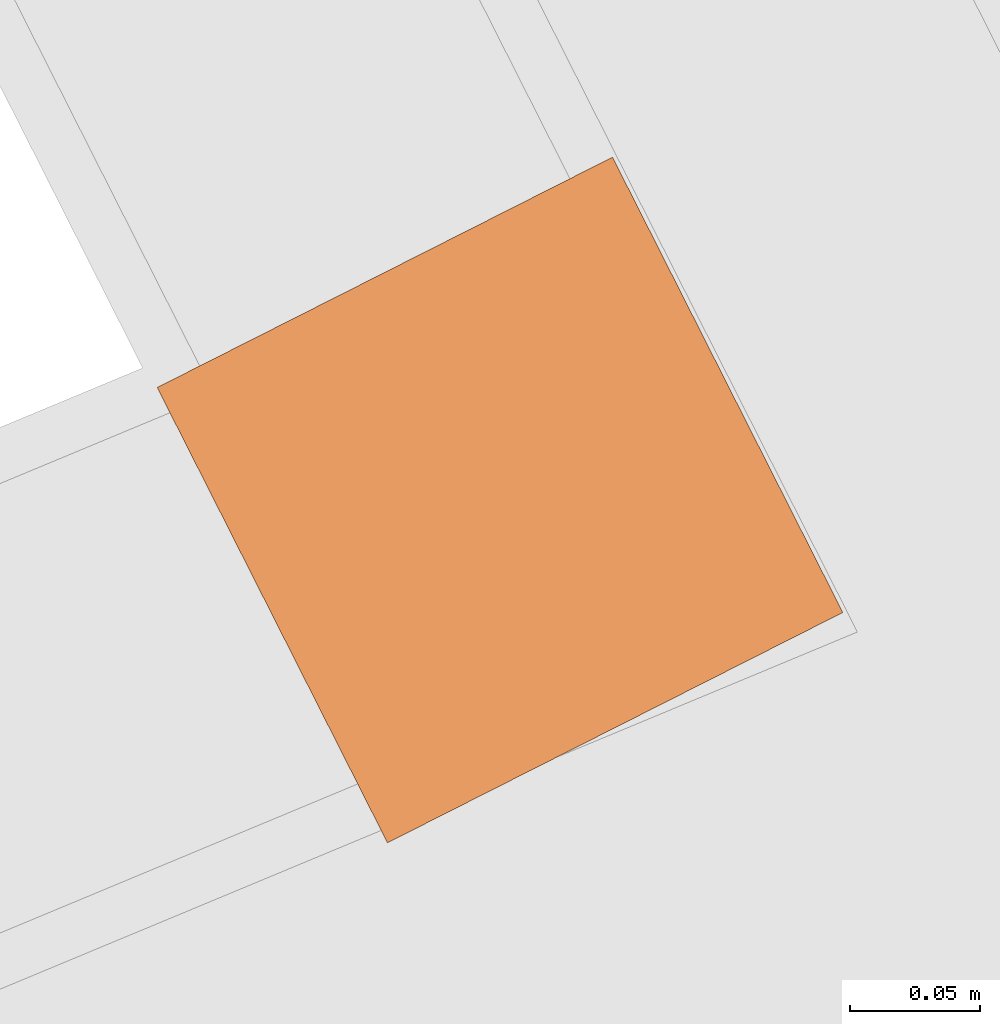
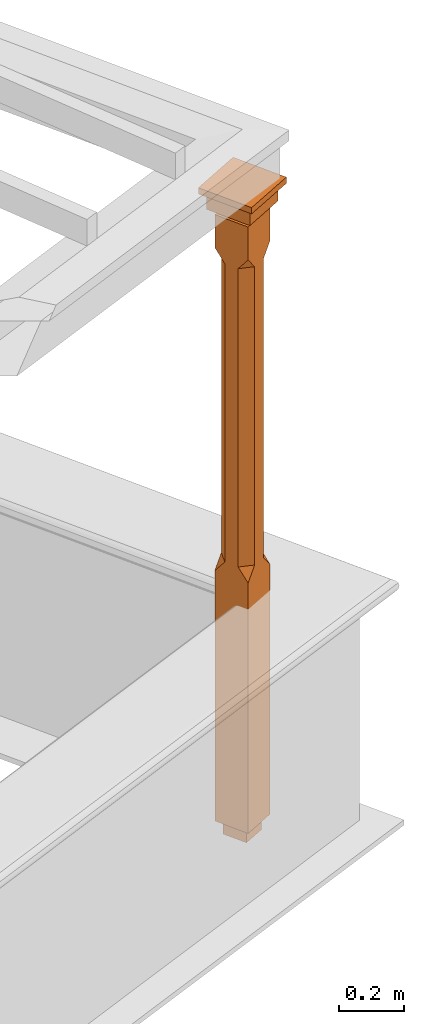
# One storey, part 10 of 10: 1 proxy.
"""IFC2X3 building model written with IfcOpenShell, lengths in metres."""

from ifc_helpers import new_model, si_unit, frame, origin, place, context, subcontext, project, spatial, faceted_brep, element, save


model = new_model("IFC2X3")

# Units and contexts
model_context = context("Model", 3, world=origin())
body_context = subcontext(model_context, "Body", "Model", "MODEL_VIEW")
ifc_project = project(units=[si_unit("PLANEANGLEUNIT", "RADIAN"), si_unit("MASSUNIT", "GRAM", prefix="KILO"), si_unit("FORCEUNIT", "NEWTON", prefix="KILO"), si_unit("LENGTHUNIT", "METRE")], contexts=[model_context])

# Site, building, storey
site_placement = place(None, origin())
site = spatial("IfcSite", under=ifc_project, at=site_placement, CompositionType="ELEMENT")
building_placement = place(None, origin())
building = spatial("IfcBuilding", under=site, at=building_placement, Name="Building plot-1", CompositionType="ELEMENT")
storey_placement = place(None, frame((0.0, 0.0, 8.45)))
storey = spatial("IfcBuildingStorey", under=building, at=storey_placement, Name="Floor 2", CompositionType="ELEMENT", Elevation=8.45)

# Proxy
proxy_placement = place(storey_placement, frame((32.3490806671408, 44.6837932061123, 0.0), z_axis=(0.0, 0.0, 1.0), x_axis=(-0.451362692390249, 0.892340585156937, 0.0)))
element("IfcBuildingElementProxy", 1, at=proxy_placement, inside=storey, Name="pergola post", CompositionType="ELEMENT", context=body_context, shape_type="Brep", held_by="IfcProductRepresentation", body=[
    faceted_brep([(0.0246, -0.0615, 2.17), (0.0615, -0.0246, 2.17), (0.0615, -0.0615, 2.216667), (0.0615, -0.0246, 1.044444), (0.0246, -0.0615, 1.044444), (0.0615, 0.0246, 2.17), (0.0615, 0.0615, 2.216667), (-0.0246, -0.0615, 2.17), (-0.0615, -0.0615, 2.216667), (-0.0246, -0.0615, 1.044444), (0.0615, -0.0615, 0.997778), (0.0615, 0.0246, 1.044444), (0.0246, 0.0615, 2.17), (0.0615, 0.0615, 2.341111), (0.0615, -0.0615, 2.341111), (-0.0615, -0.0615, 2.341111), (-0.0615, -0.0246, 2.17), (-0.0615, -0.0246, 1.044444), (-0.0615, -0.0615, 0.997778), (0.0615, 0.0615, 0.997778), (0.0246, 0.0615, 1.044444), (-0.0246, 0.0615, 2.17), (-0.0615, 0.0615, 2.216667), (0.04305, 0.04305, 2.341111), (0.04305, -0.04305, 2.341111), (-0.0615, 0.0615, 2.341111), (-0.04305, -0.04305, 2.341111), (-0.0615, 0.0246, 2.17), (-0.0615, 0.0246, 1.044444), (0.0615, -0.0615, 0.053333), (-0.0615, -0.0615, 0.053333), (0.0615, 0.0615, 0.053333), (-0.0246, 0.0615, 1.044444), (-0.04305, 0.04305, 2.341111), (0.04305, 0.04305, 2.364444), (0.04305, -0.04305, 2.364444), (-0.04305, -0.04305, 2.364444), (-0.0615, 0.0615, 0.997778), (-0.0615, 0.0615, 0.053333), (-0.04305, -0.04305, 0.053333), (0.04305, -0.04305, 0.053333), (0.04305, 0.04305, 0.053333), (-0.04305, 0.04305, 2.364444), (0.07995, 0.07995, 2.364444), (0.07995, -0.07995, 2.364444), (-0.07995, -0.07995, 2.364444), (-0.04305, 0.04305, 0.053333), (-0.04305, -0.04305, 0.0), (0.04305, -0.04305, 0.0), (0.04305, 0.04305, 0.0), (-0.07995, 0.07995, 2.364444), (0.07995, 0.07995, 2.426667), (0.07995, -0.07995, 2.426667), (-0.07995, -0.07995, 2.426667), (-0.04305, 0.04305, 0.0), (-0.07995, 0.07995, 2.426667), (0.0984, 0.0984, 2.426667), (0.0984, -0.0984, 2.426667), (-0.0984, -0.0984, 2.426667), (-0.0984, 0.0984, 2.426667), (0.0984, 0.0984, 2.45), (0.0984, -0.0984, 2.45), (-0.0984, -0.0984, 2.45), (-0.0984, 0.0984, 2.45)], [[[0, 1, 2]], [[3, 1, 0, 4]], [[1, 5, 6, 2]], [[7, 0, 2, 8]], [[4, 0, 7, 9]], [[3, 4, 10]], [[1, 3, 11, 5]], [[5, 12, 6]], [[13, 14, 2, 6]], [[15, 8, 2, 14]], [[8, 16, 7]], [[9, 7, 16, 17]], [[9, 18, 10, 4]], [[3, 10, 19, 11]], [[20, 12, 5, 11]], [[21, 22, 6, 12]], [[14, 13, 23, 24]], [[13, 6, 22, 25]], [[25, 22, 8, 15]], [[26, 15, 14, 24]], [[16, 8, 22, 27]], [[27, 28, 17, 16]], [[17, 18, 9]], [[29, 10, 18, 30]], [[31, 19, 10, 29]], [[20, 11, 19]], [[12, 20, 32, 21]], [[21, 27, 22]], [[33, 23, 13, 25]], [[23, 34, 35, 24]], [[26, 33, 25, 15]], [[36, 26, 24, 35]], [[28, 27, 21, 32]], [[17, 28, 37, 18]], [[38, 30, 18, 37]], [[29, 30, 39, 40]], [[31, 38, 37, 19]], [[40, 41, 31, 29]], [[32, 20, 19, 37]], [[33, 42, 34, 23]], [[43, 44, 35, 34]], [[42, 33, 26, 36]], [[36, 35, 44, 45]], [[28, 32, 37]], [[46, 39, 30, 38]], [[39, 47, 48, 40]], [[46, 38, 31, 41]], [[49, 41, 40, 48]], [[43, 34, 42, 50]], [[43, 51, 52, 44]], [[45, 50, 42, 36]], [[53, 45, 44, 52]], [[46, 54, 47, 39]], [[54, 46, 41, 49]], [[50, 55, 51, 43]], [[56, 57, 52, 51]], [[55, 50, 45, 53]], [[53, 52, 57, 58]], [[56, 51, 55, 59]], [[56, 60, 61, 57]], [[58, 59, 55, 53]], [[62, 58, 57, 61]], [[59, 63, 60, 56]], [[63, 62, 61, 60]], [[58, 62, 63, 59]], [[47, 54, 49, 48]]]),
])

save(model, "model.ifc")
